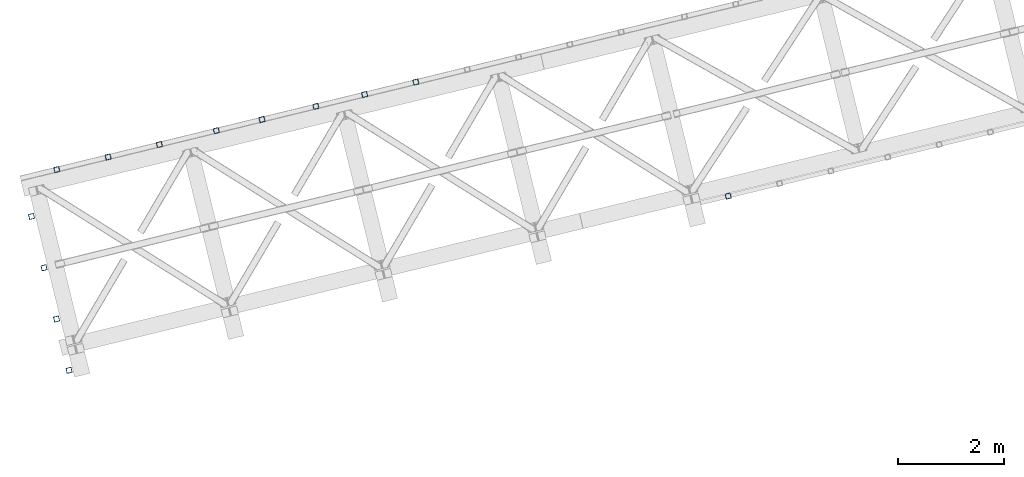
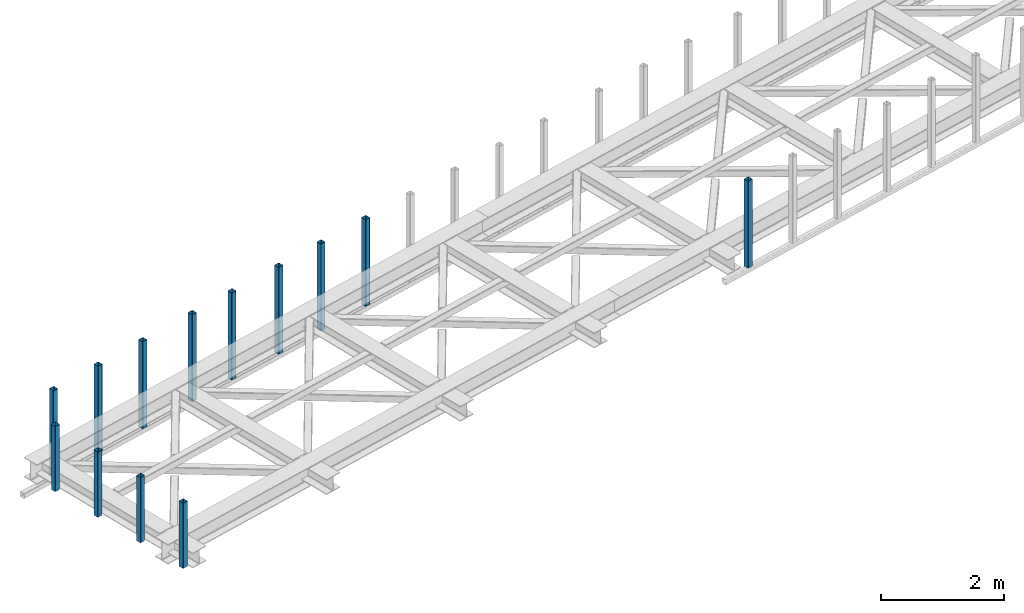
# One storey, part 1 of 67: 13 columns.
"""IFC4 building model written with IfcOpenShell, lengths in millimetres."""

from ifc_helpers import new_model, entity, si_unit, converted_unit, derived_unit, direction, frame, origin, place, context, subcontext, project, spatial, indexed_curve, outline, extrude, type_object, element, save


model = new_model("IFC4")

# Units and contexts
model_context = context("Model", 3, precision=0.01, world=origin(), true_north=direction((6.12303176911189e-17, 1.0)))
plan_context = context("Plan", 3, precision=0.01, world=origin(), true_north=direction((6.12303176911189e-17, 1.0)))
body_context = subcontext(model_context, "Body", "Model", "MODEL_VIEW")
ifc_project = project(units=[si_unit("LENGTHUNIT", "METRE", prefix="MILLI"), si_unit("AREAUNIT", "SQUARE_METRE"), si_unit("VOLUMEUNIT", "CUBIC_METRE"), converted_unit("PLANEANGLEUNIT", "DEGREE", entity("IfcRatioMeasure", 0.0174532925199433), si_unit("PLANEANGLEUNIT", "RADIAN"), dimensions=[0, 0, 0, 0, 0, 0, 0]), si_unit("MASSUNIT", "GRAM", prefix="KILO"), derived_unit("MASSDENSITYUNIT", [(si_unit("MASSUNIT", "GRAM", prefix="KILO"), 1), (si_unit("LENGTHUNIT", "METRE"), -3)]), derived_unit("MOMENTOFINERTIAUNIT", [(si_unit("LENGTHUNIT", "METRE"), 4)]), si_unit("TIMEUNIT", "SECOND"), si_unit("FREQUENCYUNIT", "HERTZ"), si_unit("THERMODYNAMICTEMPERATUREUNIT", "DEGREE_CELSIUS"), derived_unit("THERMALTRANSMITTANCEUNIT", [(si_unit("MASSUNIT", "GRAM", prefix="KILO"), 1), (si_unit("THERMODYNAMICTEMPERATUREUNIT", "KELVIN"), -1), (si_unit("TIMEUNIT", "SECOND"), -3)]), derived_unit("VOLUMETRICFLOWRATEUNIT", [(si_unit("LENGTHUNIT", "METRE"), 3), (si_unit("TIMEUNIT", "SECOND"), -1)]), derived_unit("MASSFLOWRATEUNIT", [(si_unit("MASSUNIT", "GRAM", prefix="KILO"), 1), (si_unit("TIMEUNIT", "SECOND"), -1)]), derived_unit("ROTATIONALFREQUENCYUNIT", [(si_unit("TIMEUNIT", "SECOND"), -1)]), si_unit("ELECTRICCURRENTUNIT", "AMPERE"), si_unit("ELECTRICVOLTAGEUNIT", "VOLT"), si_unit("POWERUNIT", "WATT"), si_unit("FORCEUNIT", "NEWTON", prefix="KILO"), si_unit("ILLUMINANCEUNIT", "LUX"), si_unit("LUMINOUSFLUXUNIT", "LUMEN"), si_unit("LUMINOUSINTENSITYUNIT", "CANDELA"), derived_unit("USERDEFINED", [(si_unit("MASSUNIT", "GRAM", prefix="KILO"), -1), (si_unit("LENGTHUNIT", "METRE"), -2), (si_unit("TIMEUNIT", "SECOND"), 3), (si_unit("LUMINOUSFLUXUNIT", "LUMEN"), 1)]), derived_unit("LINEARVELOCITYUNIT", [(si_unit("LENGTHUNIT", "METRE"), 1), (si_unit("TIMEUNIT", "SECOND"), -1)]), si_unit("PRESSUREUNIT", "PASCAL"), derived_unit("USERDEFINED", [(si_unit("LENGTHUNIT", "METRE"), -2), (si_unit("MASSUNIT", "GRAM", prefix="KILO"), 1), (si_unit("TIMEUNIT", "SECOND"), -2)]), derived_unit("LINEARFORCEUNIT", [(si_unit("MASSUNIT", "GRAM", prefix="KILO"), 1), (si_unit("LENGTHUNIT", "METRE"), 1), (si_unit("TIMEUNIT", "SECOND"), -2), (si_unit("LENGTHUNIT", "METRE"), -1)]), derived_unit("PLANARFORCEUNIT", [(si_unit("MASSUNIT", "GRAM", prefix="KILO"), 1), (si_unit("LENGTHUNIT", "METRE"), 1), (si_unit("TIMEUNIT", "SECOND"), -2), (si_unit("LENGTHUNIT", "METRE"), -2)])], contexts=[model_context, plan_context])

# Site, building, storey
site_placement = place(None, origin())
site = spatial("IfcSite", under=ifc_project, at=site_placement, CompositionType="ELEMENT")
building_placement = place(site_placement, origin())
building = spatial("IfcBuilding", under=site, at=building_placement, CompositionType="ELEMENT")
storey_placement = place(building_placement, frame((0.0, 0.0, 19800.0)))
storey = spatial("IfcBuildingStorey", under=building, at=storey_placement, CompositionType="ELEMENT", Elevation=19800.0)

# Columns
column_type_1 = type_object("IfcColumnType", PredefinedType="COLUMN")
column_1_placement = place(storey_placement, origin())
element("IfcColumn", 1, at=column_1_placement, inside=storey, type_object=column_type_1, ObjectType="Steel Column", PredefinedType="COLUMN", context=body_context, shape_type="SweptSolid", body=[
    extrude(outline(indexed_curve([(29.4768951153626, -56.8428769007812), (33.3787015556899, -56.8428769007812), (36.9835006657251, -55.3497202197727), (39.7424944585471, -52.5907264269386), (41.235651139549, -48.985927316902), (56.842876900785, 29.4768951153656), (56.8428769007802, 33.3787015556904), (55.3497202197698, 36.983500665724), (52.5907264269414, 39.7424944585505), (48.9859273169057, 41.2356511395544), (-29.4768951153617, 56.8428769007831), (-33.3787015556895, 56.8428769007822), (-36.9835006657251, 55.3497202197727), (-39.7424944585466, 52.5907264269396), (-41.2356511395564, 48.9859273169066), (-56.8428769007845, -29.4768951153646), (-56.8428769007793, -33.3787015556884), (-55.3497202197694, -36.983500665723), (-52.5907264269404, -39.7424944585485), (-48.9859273169048, -41.2356511395524), (29.4768951153626, -56.8428769007812)], self_intersect=False), holes=[indexed_curve([(-43.1065493048113, -37.3071763476123), (-46.7113484148549, -35.8140196666048), (-49.4703422076833, -33.0550258737783), (-50.9634988886858, -29.4502267637483), (-50.9634988886832, -25.5484203234281), (-37.3071763476124, 43.1065493048114), (-35.8140196666113, 46.711348414846), (-33.0550258737806, 49.4703422076784), (-29.4502267637533, 50.9634988886906), (-25.5484203234334, 50.9634988886952), (43.1065493048044, 37.307176347618), (46.7113484148479, 35.8140196666104), (49.4703422076764, 33.0550258737839), (50.9634988886863, 29.4502267637493), (50.9634988886924, 25.5484203234274), (37.3071763476133, -43.1065493048094), (35.8140196666035, -46.7113484148423), (33.0550258737736, -49.4703422076728), (29.4502267637464, -50.9634988886849), (25.5484203234264, -50.9634988886896), (-43.1065493048113, -37.3071763476123)], self_intersect=False)]), frame((-53814.2493232016, 7880.41144630986, 3378.0), z_axis=(0.0, 0.0, 1.0), x_axis=(0.906681479027635, 0.421815949897891, 0.0)), (0.0, 0.0, 1.0), 1720.00000000001),
])
column_type_2 = type_object("IfcColumnType", PredefinedType="COLUMN")
column_2_placement = place(storey_placement, origin())
element("IfcColumn", 2, at=column_2_placement, inside=storey, type_object=column_type_2, ObjectType="Steel Column", PredefinedType="COLUMN", context=body_context, shape_type="SweptSolid", body=[
    extrude(outline(indexed_curve([(29.4768951153024, -56.8428769008208), (33.3787015556224, -56.8428769008208), (36.9835006656593, -55.3497202198166), (39.7424944584924, -52.5907264269894), (41.2356511394987, -48.9859273169546), (56.8428769008278, 29.4768951152944), (56.8428769008277, 33.3787015556192), (55.3497202198212, 36.9835006656536), (52.5907264269881, 39.7424944584871), (48.9859273169621, 41.2356511394916), (-29.4768951152941, 56.8428769008181), (-33.3787015556141, 56.8428769008181), (-36.9835006656514, 55.349720219813), (-39.7424944584841, 52.5907264269867), (-41.2356511394908, 48.9859273169509), (-56.8428769008121, -29.4768951153017), (-56.8428769008115, -33.3787015556255), (-55.3497202198133, -36.9835006656573), (-52.5907264269798, -39.7424944584897), (-48.9859273169459, -41.2356511394979), (29.4768951153024, -56.8428769008208)], self_intersect=False), holes=[indexed_curve([(-43.1065493048478, -37.3071763475648), (-46.71134841489, -35.814019666554), (-49.4703422077148, -33.0550258737232), (-50.9634988887134, -29.4502267636924), (-50.9634988887057, -25.5484203233713), (-37.3071763475538, 43.106549304851), (-35.8140196665475, 46.7113484148858), (-33.0550258737149, 49.4703422077121), (-29.4502267636928, 50.9634988887255), (-25.5484203233654, 50.9634988887209), (43.106549304864, 37.3071763475585), (46.7113484148983, 35.8140196665513), (49.4703422077231, 33.0550258737205), (50.9634988887296, 29.4502267636861), (50.9634988887302, 25.5484203233623), (37.3071763475699, -43.1065493048573), (35.8140196665554, -46.7113484148895), (33.0550258737227, -49.4703422077157), (29.4502267637015, -50.9634988887272), (25.5484203233737, -50.9634988887236), (-43.1065493048478, -37.3071763475648)], self_intersect=False)]), frame((-54785.801381343, 7643.58535331953, 3378.0), z_axis=(0.0, 0.0, 1.0), x_axis=(0.906681479027134, 0.421815949898968, 0.0)), (0.0, 0.0, 1.0), 1720.00000000001),
])
column_type_3 = type_object("IfcColumnType", PredefinedType="COLUMN")
column_3_placement = place(storey_placement, origin())
element("IfcColumn", 3, at=column_3_placement, inside=storey, type_object=column_type_3, ObjectType="Steel Column", PredefinedType="COLUMN", context=body_context, shape_type="SweptSolid", body=[
    extrude(outline(indexed_curve([(29.4768951153557, -56.8428769007932), (33.3787015556835, -56.8428769007932), (36.9835006657111, -55.349720219782), (39.7424944585417, -52.5907264269522), (41.2356511395445, -48.985927316916), (56.8428769007924, 29.4768951153513), (56.842876900796, 33.3787015556714), (55.3497202197865, 36.9835006657054), (52.5907264269588, 39.7424944585326), (48.9859273169234, 41.2356511395375), (-29.4768951153474, 56.8428769007906), (-33.3787015556673, 56.8428769007869), (-36.9835006657033, 55.3497202197784), (-39.7424944585334, 52.5907264269495), (-41.2356511395367, 48.9859273169123), (-56.8428769007845, -29.4768951153549), (-56.8428769007881, -33.3787015556751), (-55.3497202197787, -36.9835006657091), (-52.5907264269426, -39.742494458539), (-48.9859273169073, -41.2356511395438), (29.4768951153557, -56.8428769007932)], self_intersect=False), holes=[indexed_curve([(-43.1065493048133, -37.3071763476062), (-46.7113484148565, -35.8140196665977), (-49.4703422076926, -33.0550258737678), (-50.9634988886858, -29.4502267637401), (-50.9634988886896, -25.5484203234153), (-37.3071763475941, 43.1065493048161), (-35.8140196665991, 46.711348414856), (-33.0550258737612, 49.4703422076811), (-29.4502267637405, 50.963498888698), (-25.5484203234131, 50.963498888697), (43.1065493048212, 37.3071763476025), (46.7113484148565, 35.8140196665977), (49.4703422076921, 33.0550258737668), (50.9634988887011, 29.4502267637318), (50.9634988886984, 25.5484203234136), (37.3071763476098, -43.1065493048234), (35.8140196665987, -46.711348414857), (33.0550258737612, -49.4703422076811), (29.4502267637409, -50.963498888697), (25.548420323421, -50.9634988887006), (-43.1065493048133, -37.3071763476062)], self_intersect=False)]), frame((-55708.7758365774, 7418.60056497871, 3378.0), z_axis=(0.0, 0.0, 1.0), x_axis=(0.906681479027529, 0.421815949898119, 0.0)), (0.0, 0.0, 1.0), 1720.00000000001),
])
column_type_4 = type_object("IfcColumnType", PredefinedType="COLUMN")
column_4_placement = place(storey_placement, origin())
element("IfcColumn", 4, at=column_4_placement, inside=storey, type_object=column_type_4, ObjectType="Steel Column", PredefinedType="COLUMN", context=body_context, shape_type="SweptSolid", body=[
    extrude(outline(indexed_curve([(29.4768951153621, -56.8428769007822), (33.3787015556895, -56.8428769007822), (36.9835006657246, -55.3497202197737), (39.7424944585466, -52.5907264269396), (41.2356511395569, -48.9859273169056), (56.842876900785, 29.4768951153656), (56.8428769007797, 33.3787015556894), (55.3497202197694, 36.983500665723), (52.5907264269409, 39.7424944585495), (48.9859273169052, 41.2356511395534), (-29.47689511537, 56.8428769007858), (-33.3787015556895, 56.8428769007822), (-36.9835006657251, 55.3497202197727), (-39.7424944585471, 52.5907264269386), (-41.2356511395569, 48.9859273169056), (-56.842876900785, -29.4768951153656), (-56.8428769007797, -33.3787015556894), (-55.3497202197698, -36.983500665724), (-52.5907264269409, -39.7424944585495), (-48.9859273169052, -41.2356511395534), (29.4768951153621, -56.8428769007822)], self_intersect=False), holes=[indexed_curve([(-43.1065493048118, -37.3071763476133), (-46.7113484148558, -35.8140196666067), (-49.4703422076842, -33.0550258737802), (-50.9634988886858, -29.4502267637483), (-50.9634988886841, -25.5484203234301), (-37.3071763476128, 43.1065493048104), (-35.8140196666109, 46.711348414847), (-33.0550258737815, 49.4703422076765), (-29.4502267637616, 50.9634988886932), (-25.5484203234343, 50.9634988886932), (43.1065493048035, 37.307176347616), (46.711348414847, 35.8140196666084), (49.4703422076755, 33.0550258737819), (50.9634988886858, 29.4502267637483), (50.9634988886841, 25.5484203234301), (37.3071763476128, -43.1065493048104), (35.8140196666026, -46.7113484148443), (33.0550258737727, -49.4703422076748), (29.4502267637533, -50.9634988886906), (25.548420323426, -50.9634988886905), (-43.1065493048118, -37.3071763476133)], self_intersect=False)]), frame((-56728.905497626, 7169.93316733885, 3378.0), z_axis=(0.0, 0.0, 1.0), x_axis=(0.906681479027635, 0.421815949897891, 0.0)), (0.0, 0.0, 1.0), 1720.00000000001),
])
column_type_5 = type_object("IfcColumnType", PredefinedType="COLUMN")
column_5_placement = place(storey_placement, origin())
element("IfcColumn", 5, at=column_5_placement, inside=storey, type_object=column_type_5, ObjectType="Steel Column", PredefinedType="COLUMN", context=body_context, shape_type="SweptSolid", body=[
    extrude(outline(indexed_curve([(29.4768951153783, -56.8428769007885), (33.3787015557056, -56.8428769007885), (36.9835006657408, -55.34972021978), (39.7424944585628, -52.5907264269459), (41.235651139573, -48.985927316912), (56.8428769008011, 29.4768951153592), (56.8428769007959, 33.378701555683), (55.3497202197855, 36.9835006657167), (52.5907264269571, 39.7424944585432), (48.9859273169214, 41.2356511395471), (-29.4768951153538, 56.8428769007795), (-33.3787015556738, 56.8428769007749), (-36.9835006657089, 55.3497202197664), (-39.7424944585309, 52.5907264269322), (-41.2356511395407, 48.9859273168993), (-56.8428769007688, -29.4768951153719), (-56.8428769007636, -33.3787015556957), (-55.3497202197537, -36.9835006657303), (-52.5907264269247, -39.7424944585558), (-48.9859273168891, -41.2356511395598), (29.4768951153783, -56.8428769007885)], self_intersect=False), holes=[indexed_curve([(-43.1065493047956, -37.3071763476197), (-46.7113484148392, -35.8140196666121), (-49.4703422076676, -33.0550258737856), (-50.9634988886701, -29.4502267637556), (-50.9634988886675, -25.5484203234355), (-37.3071763475967, 43.106549304804), (-35.8140196665947, 46.7113484148406), (-33.0550258737653, 49.4703422076702), (-29.4502267637371, 50.9634988886842), (-25.5484203234181, 50.9634988886869), (43.1065493048201, 37.3071763476107), (46.7113484148636, 35.8140196666031), (49.4703422076921, 33.0550258737766), (50.9634988887025, 29.450226763743), (50.9634988887081, 25.5484203234201), (37.307176347629, -43.1065493048167), (35.8140196666192, -46.7113484148496), (33.0550258737893, -49.4703422076801), (29.4502267637699, -50.9634988886959), (25.5484203234421, -50.9634988886969), (-43.1065493047956, -37.3071763476197)], self_intersect=False)]), frame((-57593.5868293719, 6959.15794457745, 3378.0), z_axis=(0.0, 0.0, 1.0), x_axis=(0.906681479027635, 0.421815949897891, 0.0)), (0.0, 0.0, 1.0), 1720.00000000001),
])
column_type_6 = type_object("IfcColumnType", PredefinedType="COLUMN")
column_6_placement = place(storey_placement, origin())
element("IfcColumn", 6, at=column_6_placement, inside=storey, type_object=column_type_6, ObjectType="Steel Column", PredefinedType="COLUMN", context=body_context, shape_type="SweptSolid", body=[
    extrude(outline(indexed_curve([(29.4768951153538, -56.8428769007795), (33.3787015556812, -56.8428769007795), (36.9835006657163, -55.349720219771), (39.7424944585383, -52.5907264269369), (41.2356511395485, -48.985927316903), (56.8428769007766, 29.4768951153682), (56.8428769007714, 33.378701555692), (55.3497202197611, 36.9835006657257), (52.5907264269326, 39.7424944585522), (48.9859273168969, 41.2356511395561), (-29.4768951153783, 56.8428769007885), (-33.3787015556983, 56.8428769007839), (-36.9835006657334, 55.3497202197754), (-39.7424944585554, 52.5907264269412), (-41.2356511395652, 48.9859273169083), (-56.8428769007933, -29.4768951153629), (-56.842876900788, -33.3787015556867), (-55.3497202197781, -36.9835006657213), (-52.5907264269492, -39.7424944585468), (-48.9859273169135, -41.2356511395508), (29.4768951153538, -56.8428769007795)], self_intersect=False), holes=[indexed_curve([(-43.1065493048205, -37.3071763476116), (-46.7113484148641, -35.8140196666041), (-49.4703422076926, -33.0550258737776), (-50.9634988886946, -29.4502267637466), (-50.9634988886924, -25.5484203234274), (-37.3071763476216, 43.106549304812), (-35.8140196666197, 46.7113484148486), (-33.0550258737898, 49.4703422076792), (-29.4502267637625, 50.9634988886913), (-25.5484203234426, 50.9634988886959), (43.1065493047952, 37.3071763476187), (46.7113484148387, 35.8140196666111), (49.4703422076672, 33.0550258737846), (50.9634988886775, 29.450226763751), (50.9634988886832, 25.5484203234281), (37.3071763476045, -43.1065493048077), (35.8140196665947, -46.7113484148406), (33.0550258737644, -49.4703422076721), (29.450226763745, -50.9634988886879), (25.5484203234172, -50.9634988886889), (-43.1065493048205, -37.3071763476116)], self_intersect=False)]), frame((-58672.0096139089, 6696.28098135818, 3378.0), z_axis=(0.0, 0.0, 1.0), x_axis=(0.906681479027635, 0.421815949897891, 0.0)), (0.0, 0.0, 1.0), 1720.00000000001),
])
column_type_7 = type_object("IfcColumnType", PredefinedType="COLUMN")
column_7_placement = place(storey_placement, origin())
element("IfcColumn", 7, at=column_7_placement, inside=storey, type_object=column_type_7, ObjectType="Steel Column", PredefinedType="COLUMN", context=body_context, shape_type="SweptSolid", body=[
    extrude(outline(indexed_curve([(29.4768951153774, -56.8428769007905), (33.3787015557047, -56.8428769007905), (36.9835006657398, -55.349720219782), (39.7424944585618, -52.5907264269478), (41.2356511395721, -48.9859273169139), (56.8428769008002, 29.4768951153573), (56.842876900795, 33.3787015556811), (55.3497202197846, 36.9835006657147), (52.5907264269561, 39.7424944585412), (48.9859273169205, 41.2356511395451), (-29.4768951153547, 56.8428769007775), (-33.3787015556747, 56.8428769007729), (-36.9835006657098, 55.3497202197644), (-39.7424944585318, 52.5907264269303), (-41.2356511395416, 48.9859273168973), (-56.8428769007697, -29.4768951153739), (-56.8428769007645, -33.3787015556977), (-55.3497202197546, -36.9835006657323), (-52.5907264269256, -39.7424944585578), (-48.98592731689, -41.2356511395617), (29.4768951153774, -56.8428769007905)], self_intersect=False), holes=[indexed_curve([(-43.1065493047965, -37.3071763476216), (-46.7113484148401, -35.8140196666141), (-49.4703422076685, -33.0550258737875), (-50.963498888671, -29.4502267637576), (-50.9634988886684, -25.5484203234374), (-37.307176347598, 43.1065493048011), (-35.8140196665961, 46.7113484148377), (-33.0550258737662, 49.4703422076682), (-29.4502267637385, 50.9634988886813), (-25.5484203234186, 50.9634988886859), (43.106549304827, 37.307176347605), (46.7113484148627, 35.8140196666011), (49.4703422076912, 33.0550258737746), (50.9634988887015, 29.450226763741), (50.9634988887068, 25.5484203234172), (37.3071763476281, -43.1065493048187), (35.8140196666183, -46.7113484148516), (33.055025873788, -49.4703422076831), (29.450226763769, -50.9634988886979), (25.5484203234412, -50.9634988886988), (-43.1065493047965, -37.3071763476216)], self_intersect=False)]), frame((-59643.5616720504, 6459.45488836784, 3378.0), z_axis=(0.0, 0.0, 1.0), x_axis=(0.906681479027635, 0.421815949897891, 0.0)), (0.0, 0.0, 1.0), 1720.00000000001),
])
column_type_8 = type_object("IfcColumnType", PredefinedType="COLUMN")
column_8_placement = place(storey_placement, origin())
element("IfcColumn", 8, at=column_8_placement, inside=storey, type_object=column_type_8, ObjectType="Steel Column", PredefinedType="COLUMN", context=body_context, shape_type="SweptSolid", body=[
    extrude(outline(indexed_curve([(29.4768951153621, -56.8428769007822), (33.3787015556895, -56.8428769007822), (36.9835006657246, -55.3497202197737), (39.7424944585466, -52.5907264269396), (41.2356511395569, -48.9859273169056), (56.842876900785, 29.4768951153656), (56.8428769007797, 33.3787015556894), (55.3497202197694, 36.983500665723), (52.5907264269409, 39.7424944585495), (48.9859273169052, 41.2356511395534), (-29.47689511537, 56.8428769007858), (-33.3787015556895, 56.8428769007822), (-36.9835006657251, 55.3497202197727), (-39.7424944585471, 52.5907264269386), (-41.2356511395569, 48.9859273169056), (-56.842876900785, -29.4768951153656), (-56.8428769007797, -33.3787015556894), (-55.3497202197698, -36.983500665724), (-52.5907264269409, -39.7424944585495), (-48.9859273169052, -41.2356511395534), (29.4768951153621, -56.8428769007822)], self_intersect=False), holes=[indexed_curve([(-43.1065493048113, -37.3071763476123), (-46.7113484148553, -35.8140196666058), (-49.4703422076838, -33.0550258737792), (-50.9634988886858, -29.4502267637483), (-50.9634988886837, -25.5484203234291), (-37.3071763476128, 43.1065493048104), (-35.8140196666109, 46.711348414847), (-33.055025873781, 49.4703422076775), (-29.4502267637533, 50.9634988886906), (-25.5484203234338, 50.9634988886942), (43.1065493048044, 37.307176347618), (46.7113484148475, 35.8140196666094), (49.4703422076764, 33.0550258737839), (50.9634988886867, 29.4502267637503), (50.963498888692, 25.5484203234265), (37.3071763476133, -43.1065493048094), (35.8140196666035, -46.7113484148423), (33.0550258737736, -49.4703422076728), (29.4502267637542, -50.9634988886886), (25.5484203234264, -50.9634988886896), (-43.1065493048113, -37.3071763476123)], self_intersect=False)]), frame((-60615.1137301919, 6222.6287953775, 3378.0), z_axis=(0.0, 0.0, 1.0), x_axis=(0.906681479027635, 0.421815949897891, 0.0)), (0.0, 0.0, 1.0), 1720.00000000001),
])
column_type_9 = type_object("IfcColumnType", PredefinedType="COLUMN")
column_9_placement = place(storey_placement, origin())
element("IfcColumn", 9, at=column_9_placement, inside=storey, type_object=column_type_9, ObjectType="Steel Column", PredefinedType="COLUMN", context=body_context, shape_type="SweptSolid", body=[
    extrude(outline(indexed_curve([(29.4768951153325, -56.8428769008207), (33.3787015556519, -56.8428769008207), (36.9835006656889, -55.3497202198146), (39.7424944585135, -52.5907264269831), (41.2356511395267, -48.9859273169515), (56.8428769008283, 29.4768951153051), (56.8428769008267, 33.3787015556289), (55.3497202198197, 36.9835006656639), (52.5907264269934, 39.742494458492), (48.9859273169595, 41.2356511395003), (-29.4768951152932, 56.8428769008024), (-33.378701555621, 56.8428769008051), (-36.9835006656575, 55.3497202198), (-39.7424944584816, 52.5907264269694), (-41.2356511394953, 48.9859273169369), (-56.8428769007968, -29.4768951153197), (-56.8428769007953, -33.3787015556435), (-55.3497202197883, -36.9835006656785), (-52.5907264269624, -39.7424944585076), (-48.9859273169281, -41.2356511395149), (29.4768951153325, -56.8428769008207)], self_intersect=False), holes=[indexed_curve([(-43.1065493048305, -37.3071763475793), (-46.7113484148653, -35.814019666573), (-49.4703422076916, -33.0550258737449), (-50.9634988886982, -29.4502267637089), (-50.9634988886993, -25.5484203233841), (-37.3071763475568, 43.106549304838), (-35.8140196665514, 46.7113484148732), (-33.055025873719, 49.4703422077011), (-29.4502267636903, 50.9634988887098), (-25.5484203233625, 50.9634988887071), (43.1065493048546, 37.3071763475693), (46.7113484148967, 35.8140196665584), (49.4703422077231, 33.0550258737303), (50.9634988887296, 29.4502267636943), (50.9634988887238, 25.5484203233751), (37.3071763475886, -43.1065493048516), (35.8140196665828, -46.7113484148878), (33.0550258737509, -49.4703422077147), (29.4502267637139, -50.9634988887208), (25.5484203233944, -50.9634988887208), (-43.1065493048305, -37.3071763475793)], self_intersect=False)]), frame((-61093.2917996946, 5334.10713900293, 3808.0), z_axis=(0.0, 0.0, 1.0), x_axis=(0.90668147902724, 0.42181594989874, 0.0)), (0.0, 0.0, 1.0), 1290.00000000001),
])
column_type_10 = type_object("IfcColumnType", PredefinedType="COLUMN")
column_10_placement = place(storey_placement, origin())
element("IfcColumn", 10, at=column_10_placement, inside=storey, type_object=column_type_10, ObjectType="Steel Column", PredefinedType="COLUMN", context=body_context, shape_type="SweptSolid", body=[
    extrude(outline(indexed_curve([(29.4768951153013, -56.8428769008144), (33.378701555621, -56.8428769008144), (36.9835006656579, -55.3497202198093), (39.7424944584829, -52.5907264269781), (41.2356511394967, -48.9859273169462), (56.8428769008082, 29.4768951153084), (56.8428769008071, 33.3787015556322), (55.3497202198006, 36.9835006656674), (52.5907264269748, 39.7424944584964), (48.9859273169405, 41.2356511395036), (-29.4768951153179, 56.8428769008198), (-33.3787015556374, 56.8428769008203), (-36.9835006656743, 55.3497202198151), (-39.742494458499, 52.5907264269844), (-41.2356511395129, 48.9859273169526), (-56.8428769008244, -29.4768951153021), (-56.8428769008233, -33.3787015556259), (-55.349720219817, -36.9835006656616), (-52.5907264269912, -39.7424944584905), (-48.9859273169571, -41.2356511394983), (29.4768951153013, -56.8428769008144)], self_intersect=False), holes=[indexed_curve([(-43.1065493048595, -37.3071763475644), (-46.7113484149015, -35.814019666553), (-49.4703422077272, -33.0550258737241), (-50.9634988887257, -29.450226763692), (-50.963498888727, -25.5484203233687), (-37.3071763475754, 43.1065493048526), (-35.8140196665696, 46.7113484148876), (-33.0550258737366, 49.4703422077157), (-29.4502267637158, 50.9634988887272), (-25.548420323388, 50.963498888724), (43.1065493048274, 37.3071763475776), (46.711348414877, 35.814019666562), (49.4703422077027, 33.0550258737331), (50.9634988887093, 29.4502267636979), (50.9634988887027, 25.5484203233782), (37.3071763475587, -43.1065493048473), (35.8140196665453, -46.7113484148782), (33.0550258737125, -49.4703422077057), (29.4502267636835, -50.9634988887145), (25.5484203233637, -50.9634988887145), (-43.1065493048595, -37.3071763475644)], self_intersect=False)]), frame((-60856.4657067042, 4362.55508086146, 3808.0), z_axis=(0.0, 0.0, 1.0), x_axis=(0.906681479027187, 0.421815949898854, 0.0)), (0.0, 0.0, 1.0), 1290.00000000001),
])
column_type_11 = type_object("IfcColumnType", PredefinedType="COLUMN")
column_11_placement = place(storey_placement, origin())
element("IfcColumn", 11, at=column_11_placement, inside=storey, type_object=column_type_11, ObjectType="Steel Column", PredefinedType="COLUMN", context=body_context, shape_type="SweptSolid", body=[
    extrude(outline(indexed_curve([(29.4768951153094, -56.8428769008176), (33.3787015556291, -56.8428769008176), (36.983500665666, -55.3497202198125), (39.742494458491, -52.5907264269812), (41.2356511395048, -48.9859273169494), (56.8428769008163, 29.4768951153052), (56.8428769008152, 33.378701555629), (55.3497202198087, 36.9835006656642), (52.5907264269829, 39.7424944584932), (48.9859273169488, 41.2356511395009), (-29.4768951153017, 56.8428769008134), (-33.3787015556293, 56.8428769008171), (-36.9835006656662, 55.349720219812), (-39.7424944584912, 52.5907264269807), (-41.2356511395048, 48.9859273169494), (-56.8428769008163, -29.4768951153052), (-56.8428769008152, -33.378701555629), (-55.3497202198089, -36.9835006656647), (-52.5907264269831, -39.7424944584937), (-48.985927316949, -41.2356511395014), (29.4768951153094, -56.8428769008176)], self_intersect=False), holes=[indexed_curve([(-43.1065493048514, -37.3071763475676), (-46.7113484148853, -35.8140196665594), (-49.4703422077113, -33.0550258737309), (-50.9634988887176, -29.4502267636952), (-50.9634988887187, -25.5484203233714), (-37.307176347567, 43.10654930485), (-35.8140196665613, 46.711348414885), (-33.0550258737285, 49.4703422077125), (-29.4502267636994, 50.9634988887213), (-25.548420323372, 50.9634988887172), (43.1065493048433, 37.3071763475707), (46.7113484148853, 35.8140196665594), (49.470342207711, 33.0550258737304), (50.9634988887176, 29.4502267636952), (50.9634988887108, 25.548420323375), (37.307176347567, -43.10654930485), (35.8140196665613, -46.711348414885), (33.0550258737285, -49.4703422077125), (29.4502267636918, -50.9634988887172), (25.5484203233718, -50.9634988887177), (-43.1065493048514, -37.3071763475676)], self_intersect=False)]), frame((-60619.6396137139, 3391.00302271999, 3808.0), z_axis=(0.0, 0.0, 1.0), x_axis=(0.906681479027187, 0.421815949898854, 0.0)), (0.0, 0.0, 1.0), 1290.00000000001),
])
column_type_12 = type_object("IfcColumnType", PredefinedType="COLUMN")
column_12_placement = place(storey_placement, origin())
element("IfcColumn", 12, at=column_12_placement, inside=storey, type_object=column_type_12, ObjectType="Steel Column", PredefinedType="COLUMN", context=body_context, shape_type="SweptSolid", body=[
    extrude(outline(indexed_curve([(29.476895115314, -56.8428769008224), (33.3787015556338, -56.8428769008224), (36.9835006656707, -55.3497202198177), (39.7424944584958, -52.5907264269867), (41.2356511395098, -48.9859273169552), (56.8428769008263, 29.4768951152987), (56.8428769008255, 33.3787015556225), (55.3497202198192, 36.9835006656578), (52.5907264269936, 39.742494458487), (48.9859273169596, 41.2356511394949), (-29.4768951152902, 56.8428769008119), (-33.3787015556175, 56.8428769008163), (-36.9835006656546, 55.3497202198114), (-39.7424944584797, 52.5907264269803), (-41.2356511394935, 48.9859273169491), (-56.84287690081, -29.4768951153048), (-56.8428769008092, -33.3787015556286), (-55.349720219803, -36.9835006656642), (-52.5907264269774, -39.7424944584933), (-48.9859273169434, -41.2356511395013), (29.476895115314, -56.8428769008224)], self_intersect=False), holes=[indexed_curve([(-43.1065493048456, -37.3071763475678), (-46.7113484148796, -35.8140196665598), (-49.4703422077052, -33.0550258737307), (-50.9634988887113, -29.4502267636951), (-50.9634988887123, -25.5484203233716), (-37.3071763475564, 43.1065493048489), (-35.8140196665504, 46.7113484148838), (-33.0550258737174, 49.4703422077112), (-29.4502267636882, 50.9634988887198), (-25.5484203233606, 50.9634988887159), (43.1065493048539, 37.3071763475651), (46.7113484148957, 35.8140196665535), (49.4703422077211, 33.0550258737239), (50.9634988887274, 29.4502267636886), (50.9634988887206, 25.5484203233689), (37.3071763475724, -43.1065493048555), (35.8140196665664, -46.7113484148904), (33.0550258737336, -49.4703422077175), (29.4502267636964, -50.9634988887227), (25.5484203233768, -50.9634988887222), (-43.1065493048456, -37.3071763475678)], self_intersect=False)]), frame((-60382.8135207236, 2419.45096457852, 3808.0), z_axis=(0.0, 0.0, 1.0), x_axis=(0.90668147902716, 0.421815949898911, 0.0)), (0.0, 0.0, 1.0), 1290.00000000001),
])
column_type_13 = type_object("IfcColumnType", PredefinedType="COLUMN")
column_13_placement = place(storey_placement, origin())
element("IfcColumn", 13, at=column_13_placement, inside=storey, type_object=column_type_13, ObjectType="Steel Column", PredefinedType="COLUMN", context=body_context, shape_type="SweptSolid", body=[
    extrude(outline(indexed_curve([(29.4768951153272, -56.8428769007868), (33.3787015556517, -56.8428769007868), (36.9835006656889, -55.3497202197785), (39.7424944585122, -52.5907264269475), (41.2356511395214, -48.985927316913), (56.8428769008053, 29.4768951153436), (56.8428769008064, 33.3787015556652), (55.3497202197981, 36.9835006657), (52.5907264269709, 39.7424944585263), (48.9859273169297, 41.2356511395339), (-29.4768951153267, 56.8428769007878), (-33.3787015556517, 56.8428769007868), (-36.9835006656884, 55.3497202197795), (-39.7424944585122, 52.5907264269475), (-41.2356511395214, 48.985927316913), (-56.8428769008053, -29.4768951153436), (-56.8428769008059, -33.3787015556642), (-55.3497202197977, -36.983500665699), (-52.5907264269709, -39.7424944585263), (-48.9859273169297, -41.2356511395339), (29.4768951153272, -56.8428769007868)], self_intersect=False), holes=[indexed_curve([(-43.1065493048404, -37.3071763475933), (-46.7113484148742, -35.8140196665904), (-49.4703422077084, -33.0550258737584), (-50.9634988887093, -29.4502267637283), (-50.9634988887161, -25.548420323403), (-37.3071763475836, 43.1065493048179), (-35.8140196665748, 46.7113484148513), (-33.055025873751, 49.4703422076834), (-29.4502267637222, 50.9634988886944), (-25.5484203233889, 50.9634988886927), (43.10654930484, 37.3071763475923), (46.7113484148738, 35.8140196665894), (49.470342207701, 33.0550258737631), (50.963498888701, 29.450226763731), (50.9634988887082, 25.5484203234067), (37.3071763475762, -43.1065493048132), (35.8140196665753, -46.7113484148503), (33.0550258737589, -49.4703422076871), (29.4502267637143, -50.9634988886907), (25.5484203233889, -50.9634988886927), (-43.1065493048404, -37.3071763475933)], self_intersect=False)]), frame((-47899.0447717413, 5719.65658845363, 3378.00547534636), z_axis=(0.0, 0.0, 1.0), x_axis=(-0.904974271849307, -0.425466293953842, 0.0)), (0.0, 0.0, 1.0), 1719.99999999989),
])

save(model, "model.ifc")
